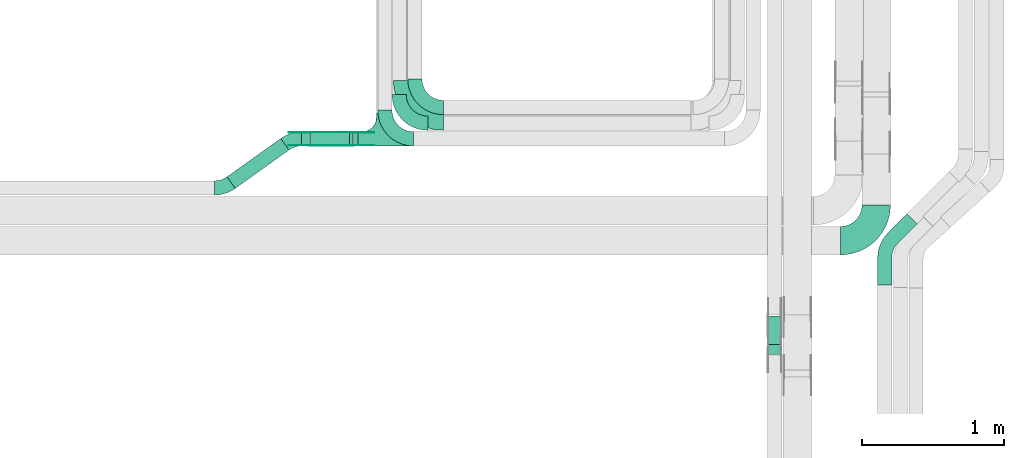
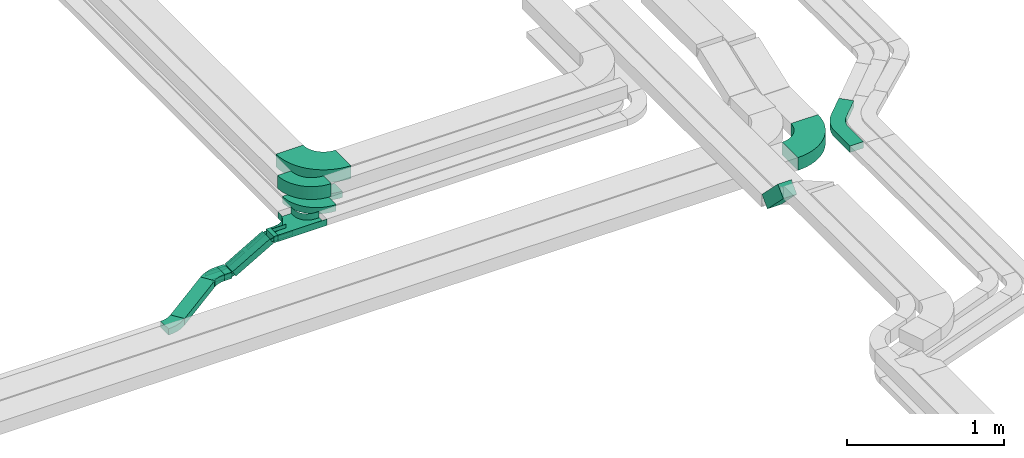
# One storey, part 21 of 25: 17 flow fittings, 5 flow segments.
"""IFC2X3 building model written with IfcOpenShell, lengths in millimetres."""

from ifc_helpers import new_model, entity, si_unit, converted_unit, derived_unit, direction, frame, frame_2d, origin, origin_2d_with_axis, place, context, subcontext, project, spatial, polyline, circle_curve, parameter, trimmed, segment, composite_curve, rectangle, outline, extrude, faceted_brep, source, transform, mapped, material, type_object, type_shapes, element, save


model = new_model("IFC2X3")

# Units and contexts
model_context = context("Model", 3, precision=0.01, world=origin(), true_north=direction((6.12303176911189e-17, 1.0)))
body_context = subcontext(model_context, "Body", "Model", "MODEL_VIEW")
ifc_project = project(units=[si_unit("LENGTHUNIT", "METRE", prefix="MILLI"), si_unit("AREAUNIT", "SQUARE_METRE"), si_unit("VOLUMEUNIT", "CUBIC_METRE"), converted_unit("PLANEANGLEUNIT", "DEGREE", entity("IfcRatioMeasure", 0.0174532925199433), si_unit("PLANEANGLEUNIT", "RADIAN"), dimensions=[0, 0, 0, 0, 0, 0, 0]), si_unit("MASSUNIT", "GRAM", prefix="KILO"), derived_unit("MASSDENSITYUNIT", [(si_unit("MASSUNIT", "GRAM", prefix="KILO"), 1), (si_unit("LENGTHUNIT", "METRE"), -3)]), derived_unit("MOMENTOFINERTIAUNIT", [(si_unit("LENGTHUNIT", "METRE"), 4)]), si_unit("TIMEUNIT", "SECOND"), si_unit("FREQUENCYUNIT", "HERTZ"), si_unit("THERMODYNAMICTEMPERATUREUNIT", "DEGREE_CELSIUS"), derived_unit("THERMALTRANSMITTANCEUNIT", [(si_unit("MASSUNIT", "GRAM", prefix="KILO"), 1), (si_unit("THERMODYNAMICTEMPERATUREUNIT", "KELVIN"), -1), (si_unit("TIMEUNIT", "SECOND"), -3)]), derived_unit("VOLUMETRICFLOWRATEUNIT", [(si_unit("LENGTHUNIT", "METRE"), 3), (si_unit("TIMEUNIT", "SECOND"), -1)]), derived_unit("MASSFLOWRATEUNIT", [(si_unit("MASSUNIT", "GRAM", prefix="KILO"), 1), (si_unit("TIMEUNIT", "SECOND"), -1)]), derived_unit("ROTATIONALFREQUENCYUNIT", [(si_unit("TIMEUNIT", "SECOND"), -1)]), si_unit("ELECTRICCURRENTUNIT", "AMPERE"), si_unit("ELECTRICVOLTAGEUNIT", "VOLT"), si_unit("POWERUNIT", "WATT"), si_unit("FORCEUNIT", "NEWTON", prefix="KILO"), si_unit("ILLUMINANCEUNIT", "LUX"), si_unit("LUMINOUSFLUXUNIT", "LUMEN"), si_unit("LUMINOUSINTENSITYUNIT", "CANDELA"), derived_unit("USERDEFINED", [(si_unit("MASSUNIT", "GRAM", prefix="KILO"), -1), (si_unit("LENGTHUNIT", "METRE"), -2), (si_unit("TIMEUNIT", "SECOND"), 3), (si_unit("LUMINOUSFLUXUNIT", "LUMEN"), 1)]), derived_unit("LINEARVELOCITYUNIT", [(si_unit("LENGTHUNIT", "METRE"), 1), (si_unit("TIMEUNIT", "SECOND"), -1)]), si_unit("PRESSUREUNIT", "PASCAL"), derived_unit("USERDEFINED", [(si_unit("LENGTHUNIT", "METRE"), -2), (si_unit("MASSUNIT", "GRAM", prefix="KILO"), 1), (si_unit("TIMEUNIT", "SECOND"), -2)]), derived_unit("LINEARFORCEUNIT", [(si_unit("MASSUNIT", "GRAM", prefix="KILO"), 1), (si_unit("LENGTHUNIT", "METRE"), 1), (si_unit("TIMEUNIT", "SECOND"), -2), (si_unit("LENGTHUNIT", "METRE"), -1)]), derived_unit("PLANARFORCEUNIT", [(si_unit("MASSUNIT", "GRAM", prefix="KILO"), 1), (si_unit("LENGTHUNIT", "METRE"), 1), (si_unit("TIMEUNIT", "SECOND"), -2), (si_unit("LENGTHUNIT", "METRE"), -2)])], contexts=[model_context])

# Site, building, storey
site_placement = place(None, frame((0.0, -0.00077364408347762, 0.0)))
site = spatial("IfcSite", under=ifc_project, at=site_placement, CompositionType="ELEMENT")
building_placement = place(site_placement, origin())
building = spatial("IfcBuilding", under=site, at=building_placement, CompositionType="ELEMENT")
storey_placement = place(building_placement, frame((0.0, 0.0, 24000.0)))
storey = spatial("IfcBuildingStorey", under=building, at=storey_placement, CompositionType="ELEMENT", Elevation=24000.0)

# Flow segments
cable_carrier_segment_type = type_object("IfcCableCarrierSegmentType", PredefinedType="CABLETRAYSEGMENT")
flow_segment_1_placement = place(storey_placement, frame((64748.84171246, 9500.0, 2972.82677247422)))
element("IfcFlowSegment", 1, at=flow_segment_1_placement, inside=storey, type_object=cable_carrier_segment_type, context=body_context, shape_type="SweptSolid", body=[
    extrude(rectangle(XDim=31.2393327962174, YDim=100.000000000001, at=origin_2d_with_axis()), frame((15.6196663981087, 50.0, 0.0), z_axis=(0.0, 0.0, 1.0), x_axis=(-1.0, 0.0, 0.0)), (0.0, 0.0, 1.0), 49.9999999999973),
])
flow_segment_2_placement = place(storey_placement, frame((64385.5720720537, 9500.0, 2805.0)))
element("IfcFlowSegment", 2, at=flow_segment_2_placement, inside=storey, type_object=cable_carrier_segment_type, context=body_context, shape_type="SweptSolid", body=[
    extrude(rectangle(XDim=54.6374214492034, YDim=99.9999999999989, at=origin_2d_with_axis()), frame((27.3187107246017, 50.0, 0.0)), (0.0, 0.0, 1.0), 49.9999999999973),
])
flow_segment_3_placement = place(storey_placement, frame((64444.0736377189, 9500.0, 2812.71695756239)))
element("IfcFlowSegment", 3, at=flow_segment_3_placement, inside=storey, type_object=cable_carrier_segment_type, context=body_context, shape_type="SweptSolid", body=[
    extrude(rectangle(XDim=49.9999999999914, YDim=100.000000000001, at=frame_2d((-3.75344200165273e-12, 0.0), x_axis=(1.0, 0.0))), frame((12.4862609703847, 50.0, 21.6585615168506), z_axis=(0.866342460674002, 0.0, 0.49945043881582), x_axis=(-0.49945043881582, 0.0, 0.866342460674002)), (0.0, 0.0, 1.0), 318.501540799204),
])
flow_segment_4_placement = place(storey_placement, frame((63861.3672984332, 9202.1366043859, 2805.0)))
element("IfcFlowSegment", 4, at=flow_segment_4_placement, inside=storey, type_object=cable_carrier_segment_type, context=body_context, shape_type="SweptSolid", body=[
    extrude(rectangle(XDim=463.396528175245, YDim=100.000000000006, at=frame_2d((3.5385028240853e-12, -2.51176857091195e-12), x_axis=(1.0, 0.0))), frame((217.602862273529, 175.358011276961, 0.0), z_axis=(0.0, 0.0, 1.0), x_axis=(-0.813735449455938, -0.581235424160247, 0.0)), (0.0, 0.0, 1.0), 49.9999999999973),
])
flow_segment_5_placement = place(storey_placement, frame((67656.3475285466, 8034.48081461932, 2986.43610045596)))
element("IfcFlowSegment", 5, at=flow_segment_5_placement, inside=storey, type_object=cable_carrier_segment_type, context=body_context, shape_type="SweptSolid", body=[
    extrude(rectangle(XDim=100.000000000001, YDim=99.9999999999946, at=frame_2d((0.0, 2.67519340013678e-12), x_axis=(0.0, 1.0))), frame((50.0, 237.9302604638, 35.35533905932), z_axis=(0.0, -0.70710678118652, 0.707106781186575), x_axis=(1.0, 0.0, 0.0)), (0.0, 0.0, 1.0), 286.484201246877),
])

# Flow fittings
ifc_material_1 = material(Name="G")
cable_carrier_fitting_type_1 = type_object("IfcCableCarrierFittingType", PredefinedType="NOTDEFINED", material=ifc_material_1)
shared_shape_1 = source(origin(), body_context, "Body", "SweptSolid", [
    extrude(outline(composite_curve([segment(trimmed(circle_curve(frame_2d((-44.5901162790698, 0.0), x_axis=(1.0, 0.0)), 12.5), [parameter(90.0000000000007)], [parameter(270.0)], True, "PARAMETER"), True, "CONTINUOUS"), segment(polyline([(-44.5901162790697, -12.5), (-33.0901162790698, -12.5)]), True, "CONTINUOUS"), segment(polyline([(-33.0901162790698, -12.5), (-31.2296511627907, -14.5)]), True, "CONTINUOUS"), segment(polyline([(-31.2296511627907, -14.5), (108.90988372093, -14.5)]), True, "CONTINUOUS"), segment(polyline([(108.90988372093, -14.5), (108.90988372093, 14.5)]), True, "CONTINUOUS"), segment(polyline([(108.90988372093, 14.5), (-31.2296511627907, 14.5)]), True, "CONTINUOUS"), segment(polyline([(-31.2296511627907, 14.5), (-33.0901162790698, 12.5)]), True, "CONTINUOUS"), segment(polyline([(-33.0901162790698, 12.5), (-44.5901162790699, 12.5)]), True, "CONTINUOUS")], self_intersect=False)), frame((44.5901162790698, 0.0, 0.0), z_axis=(0.0, 0.0, -1.0), x_axis=(1.0, 0.0, 0.0)), (0.0, 0.0, -1.0), 2.0),
])
type_shapes(cable_carrier_fitting_type_1, [shared_shape_1])
for number, where, z_axis, x_axis in (
    (6, (64740.0810452562, 9504.5399999898, 2997.82677247423), (0.0, -1.0, 0.0), (-0.866342460673953, 0.0, -0.499450438815904)),
    (7, (64448.9701607067, 9504.5399999898, 2830.0), (0.0, -1.0, 0.0), (0.866342460673953, 0.0, 0.499450438815904)),
):
    element("IfcFlowFitting", number, at=place(storey_placement, frame(where, z_axis=z_axis, x_axis=x_axis)), inside=storey, type_object=cable_carrier_fitting_type_1, material=ifc_material_1, context=body_context, shape_type="MappedRepresentation", body=[
        mapped(shared_shape_1, transform((0.0, 0.0, 0.0), scale=1.0)),
    ])
cable_carrier_fitting_type_2 = type_object("IfcCableCarrierFittingType", PredefinedType="NOTDEFINED", material=ifc_material_1)
shared_shape_2 = source(origin(), body_context, "Body", "SweptSolid", [
    extrude(outline(composite_curve([segment(trimmed(circle_curve(frame_2d((-44.5901162790697, 0.0), x_axis=(1.0, 0.0)), 12.5), [parameter(90.0000000000007)], [parameter(270.0)], True, "PARAMETER"), True, "CONTINUOUS"), segment(polyline([(-44.5901162790697, -12.5), (-33.0901162790697, -12.5)]), True, "CONTINUOUS"), segment(polyline([(-33.0901162790697, -12.5), (-31.2296511627907, -14.5)]), True, "CONTINUOUS"), segment(polyline([(-31.2296511627907, -14.5), (108.90988372093, -14.5)]), True, "CONTINUOUS"), segment(polyline([(108.90988372093, -14.5), (108.90988372093, 14.5)]), True, "CONTINUOUS"), segment(polyline([(108.90988372093, 14.5), (-31.2296511627907, 14.5)]), True, "CONTINUOUS"), segment(polyline([(-31.2296511627907, 14.5), (-33.0901162790698, 12.5)]), True, "CONTINUOUS"), segment(polyline([(-33.0901162790698, 12.5), (-44.5901162790699, 12.5)]), True, "CONTINUOUS")], self_intersect=False)), frame((44.5901162790697, 0.0, 0.0)), (0.0, 0.0, 1.0), 2.0),
])
type_shapes(cable_carrier_fitting_type_2, [shared_shape_2])
for number, where, z_axis, x_axis in (
    (8, (64740.0810452562, 9595.46000001012, 2997.82677247423), (0.0, 1.0, 0.0), (-0.866342460673953, 0.0, -0.499450438815904)),
    (9, (64448.9701607067, 9595.46000001012, 2830.0), (0.0, 1.0, 0.0), (0.866342460673953, 0.0, 0.499450438815904)),
):
    element("IfcFlowFitting", number, at=place(storey_placement, frame(where, z_axis=z_axis, x_axis=x_axis)), inside=storey, type_object=cable_carrier_fitting_type_2, material=ifc_material_1, context=body_context, shape_type="MappedRepresentation", body=[
        mapped(shared_shape_2, transform((0.0, 0.0, 0.0), scale=1.0)),
    ])
cable_carrier_fitting_type_3 = type_object("IfcCableCarrierFittingType", PredefinedType="NOTDEFINED", material=ifc_material_1)
shared_shape_3 = source(origin(), body_context, "Body", "SweptSolid", [
    extrude(outline(composite_curve([segment(trimmed(circle_curve(frame_2d((-44.5901162790698, 0.0), x_axis=(1.0, 0.0)), 12.5), [parameter(90.0000000000007)], [parameter(270.0)], True, "PARAMETER"), True, "CONTINUOUS"), segment(polyline([(-44.5901162790697, -12.5), (-33.0901162790698, -12.5)]), True, "CONTINUOUS"), segment(polyline([(-33.0901162790698, -12.5), (-31.2296511627907, -14.5)]), True, "CONTINUOUS"), segment(polyline([(-31.2296511627907, -14.5), (108.90988372093, -14.5)]), True, "CONTINUOUS"), segment(polyline([(108.90988372093, -14.5), (108.90988372093, 14.5)]), True, "CONTINUOUS"), segment(polyline([(108.90988372093, 14.5), (-31.2296511627907, 14.5)]), True, "CONTINUOUS"), segment(polyline([(-31.2296511627907, 14.5), (-33.0901162790698, 12.5)]), True, "CONTINUOUS"), segment(polyline([(-33.0901162790698, 12.5), (-44.5901162790699, 12.5)]), True, "CONTINUOUS")], self_intersect=False)), frame((44.5901162790698, 0.0, 0.0), z_axis=(0.0, 0.0, -1.0), x_axis=(1.0, 0.0, 0.0)), (0.0, 0.0, -1.0), 2.0),
])
type_shapes(cable_carrier_fitting_type_3, [shared_shape_3])
for number, where, z_axis, x_axis in (
    (10, (64740.0810452562, 9593.46000001012, 2997.82677247423), (0.0, 1.0, 0.0), (1.0, 0.0, 0.0)),
    (11, (64448.9701607067, 9593.46000001012, 2830.0), (0.0, 1.0, 0.0), (-1.0, 0.0, 0.0)),
):
    element("IfcFlowFitting", number, at=place(storey_placement, frame(where, z_axis=z_axis, x_axis=x_axis)), inside=storey, type_object=cable_carrier_fitting_type_3, material=ifc_material_1, context=body_context, shape_type="MappedRepresentation", body=[
        mapped(shared_shape_3, transform((0.0, 0.0, 0.0), scale=1.0)),
    ])
cable_carrier_fitting_type_4 = type_object("IfcCableCarrierFittingType", PredefinedType="NOTDEFINED", material=ifc_material_1)
shared_shape_4 = source(origin(), body_context, "Body", "SweptSolid", [
    extrude(outline(composite_curve([segment(trimmed(circle_curve(frame_2d((-44.5901162790697, 0.0), x_axis=(1.0, 0.0)), 12.5), [parameter(90.0000000000007)], [parameter(270.0)], True, "PARAMETER"), True, "CONTINUOUS"), segment(polyline([(-44.5901162790697, -12.5), (-33.0901162790697, -12.5)]), True, "CONTINUOUS"), segment(polyline([(-33.0901162790697, -12.5), (-31.2296511627907, -14.5)]), True, "CONTINUOUS"), segment(polyline([(-31.2296511627907, -14.5), (108.90988372093, -14.5)]), True, "CONTINUOUS"), segment(polyline([(108.90988372093, -14.5), (108.90988372093, 14.5)]), True, "CONTINUOUS"), segment(polyline([(108.90988372093, 14.5), (-31.2296511627907, 14.5)]), True, "CONTINUOUS"), segment(polyline([(-31.2296511627907, 14.5), (-33.0901162790698, 12.5)]), True, "CONTINUOUS"), segment(polyline([(-33.0901162790698, 12.5), (-44.5901162790699, 12.5)]), True, "CONTINUOUS")], self_intersect=False)), frame((44.5901162790697, 0.0, 0.0)), (0.0, 0.0, 1.0), 2.0),
])
type_shapes(cable_carrier_fitting_type_4, [shared_shape_4])
for number, where, z_axis, x_axis in (
    (12, (64740.0810452562, 9506.5399999898, 2997.82677247422), (0.0, -1.0, 0.0), (1.0, 0.0, 0.0)),
    (13, (64448.9701607067, 9506.5399999898, 2830.0), (0.0, -1.0, 0.0), (-1.0, 0.0, 0.0)),
):
    element("IfcFlowFitting", number, at=place(storey_placement, frame(where, z_axis=z_axis, x_axis=x_axis)), inside=storey, type_object=cable_carrier_fitting_type_4, material=ifc_material_1, context=body_context, shape_type="MappedRepresentation", body=[
        mapped(shared_shape_4, transform((0.0, 0.0, 0.0), scale=1.0)),
    ])
ifc_material_2 = material()
cable_carrier_fitting_type_5 = type_object("IfcCableCarrierFittingType", Name="470_DKC_S5_Variable Angle Elbow 0-45:-", PredefinedType="NOTDEFINED", material=ifc_material_2)
shared_shape_5 = source(origin(), body_context, "Body", "SweptSolid", [
    extrude(outline(composite_curve([segment(polyline([(-125.750000000001, -225.25), (-124.749999999999, -225.25)]), True, "CONTINUOUS"), segment(trimmed(circle_curve(frame_2d((-124.75, 124.75), x_axis=(0.0, -1.0)), 350.0), [parameter(0.0)], [parameter(90.0000000000001)], True, "PARAMETER"), True, "CONTINUOUS"), segment(polyline([(225.25, 124.75), (225.25, 125.749999999999)]), True, "CONTINUOUS"), segment(polyline([(225.25, 125.749999999999), (25.25, 125.750000000001)]), True, "CONTINUOUS"), segment(polyline([(25.25, 125.750000000001), (25.25, 124.75)]), True, "CONTINUOUS"), segment(trimmed(circle_curve(frame_2d((-124.75, 124.75), x_axis=(0.0, -1.0)), 150.0), [parameter(0.0)], [parameter(90.0000000000001)], True, "PARAMETER"), False, "CONTINUOUS"), segment(polyline([(-124.749999999999, -25.2500000000003), (-125.750000000001, -25.2500000000003)]), True, "CONTINUOUS"), segment(polyline([(-125.750000000001, -25.2500000000003), (-125.750000000001, -225.25)]), True, "CONTINUOUS")], self_intersect=False)), frame((-125.249999999991, 125.249999999992, -50.0)), (0.0, 0.0, 1.0), 100.0),
])
type_shapes(cable_carrier_fitting_type_5, [shared_shape_5])
flow_fitting_1_placement = place(storey_placement, frame((65130.0810452562, 9710.0, 3237.82677247422), z_axis=(0.0, 0.0, 1.0), x_axis=(0.0, -1.0, 0.0)))
element("IfcFlowFitting", 14, at=flow_fitting_1_placement, inside=storey, type_object=cable_carrier_fitting_type_5, material=ifc_material_2, Name="470_DKC_S5_Variable Angle Elbow 0-45:-", ObjectType="470_DKC_S5_Variable Angle Elbow 0-45:-", context=body_context, shape_type="MappedRepresentation", body=[
    mapped(shared_shape_5, transform((0.0, 0.0, 0.0), scale=1.0)),
])
flow_fitting_2_placement = place(storey_placement, frame((68419.2384978797, 8834.98923132602, 2855.0)))
element("IfcFlowFitting", 15, at=flow_fitting_2_placement, inside=storey, type_object=cable_carrier_fitting_type_5, material=ifc_material_2, Name="470_DKC_S5_Variable Angle Elbow 0-45:-", ObjectType="470_DKC_S5_Variable Angle Elbow 0-45:-", context=body_context, shape_type="MappedRepresentation", body=[
    mapped(shared_shape_5, transform((0.0, 0.0, 0.0), scale=1.0)),
])
cable_carrier_fitting_type_6 = type_object("IfcCableCarrierFittingType", Name="470_DKC_S5_Variable Angle Elbow 0-45:-", PredefinedType="NOTDEFINED", material=ifc_material_2)
shared_shape_6 = source(origin(), body_context, "Body", "SweptSolid", [
    extrude(outline(composite_curve([segment(polyline([(-100.749999999999, -150.250000000001), (-99.7499999999981, -150.250000000001)]), True, "CONTINUOUS"), segment(trimmed(circle_curve(frame_2d((-99.7500000000006, 99.7499999999987), x_axis=(0.0, -1.0)), 250.0), [parameter(0.0)], [parameter(90.0000000000001)], True, "PARAMETER"), True, "CONTINUOUS"), segment(polyline([(150.249999999999, 99.7500000000013), (150.249999999999, 100.750000000001)]), True, "CONTINUOUS"), segment(polyline([(150.249999999999, 100.750000000001), (50.2499999999992, 100.750000000001)]), True, "CONTINUOUS"), segment(polyline([(50.2499999999992, 100.750000000001), (50.2499999999992, 99.7500000000002)]), True, "CONTINUOUS"), segment(trimmed(circle_curve(frame_2d((-99.7500000000006, 99.7499999999987), x_axis=(0.0, -1.0)), 150.0), [parameter(0.0)], [parameter(90.0000000000001)], True, "PARAMETER"), False, "CONTINUOUS"), segment(polyline([(-99.7499999999989, -50.2500000000011), (-100.75, -50.2500000000011)]), True, "CONTINUOUS"), segment(polyline([(-100.75, -50.2500000000011), (-100.749999999999, -150.250000000001)]), True, "CONTINUOUS")], self_intersect=False)), frame((-100.249999999991, 100.249999999992, -50.0)), (0.0, 0.0, 1.0), 100.0),
])
type_shapes(cable_carrier_fitting_type_6, [shared_shape_6])
flow_fitting_3_placement = place(storey_placement, frame((64970.0810452562, 9550.0, 3237.82677247422), z_axis=(0.0, 0.0, 1.0), x_axis=(0.0, -1.0, 0.0)))
element("IfcFlowFitting", 16, at=flow_fitting_3_placement, inside=storey, type_object=cable_carrier_fitting_type_6, material=ifc_material_2, Name="470_DKC_S5_Variable Angle Elbow 0-45:-", ObjectType="470_DKC_S5_Variable Angle Elbow 0-45:-", context=body_context, shape_type="MappedRepresentation", body=[
    mapped(shared_shape_6, transform((0.0, 0.0, 0.0), scale=1.0)),
])
cable_carrier_fitting_type_7 = type_object("IfcCableCarrierFittingType", PredefinedType="NOTDEFINED", material=ifc_material_2)
shared_shape_7 = source(origin(), body_context, "Body", "Brep", [
    faceted_brep([(-53.4074173710859, -124.118095489752, 25.0), (-50.0, -150.0, 25.0), (-50.0, -180.0, 25.0), (-49.1999999999934, -180.0, 25.0), (-49.1999999999926, -150.0, 25.0), (-52.6346767100545, -123.91104025367, 25.0), (-62.7046392985216, -99.6000000000037, 25.0), (-78.7236364563899, -78.7236364563991, 25.0), (-99.5999999999949, -62.7046392985315, 25.0), (-123.911040253662, -52.6346767100651, 25.0), (-150.0, -49.2000000000047, 25.0), (-180.0, -49.2000000000047, 25.0), (-180.0, -50.0, 25.0), (-150.0, -50.0, 25.0), (-124.118095489745, -53.4074173710983, 25.0), (-100.0, -63.3974596215602, 25.0), (-79.2893218813398, -79.2893218813488, 25.0), (-63.3974596215496, -100.0, 25.0), (180.0, -50.0, 25.0), (180.0, -49.2000000000047, 25.0), (150.0, -49.2000000000046, 25.0), (123.911040253717, -52.634676710066, 25.0), (99.6000000000452, -62.7046392985316, 25.0), (78.7236364564342, -78.7236364563979, 25.0), (62.7046392985581, -99.6000000000012, 25.0), (52.6346767100809, -123.911040253668, 25.0), (49.200000000007, -150.0, 25.0), (49.2000000000071, -180.0, 25.0), (50.0, -180.0, 25.0), (50.0, -150.0, 25.0), (53.4074173711136, -124.11809548975, 25.0), (63.3974596215874, -100.0, 25.0), (79.2893218813853, -79.2893218813486, 25.0), (100.0, -63.3974596215613, 25.0), (124.1180954898, -53.4074173710999, 25.0), (150.0, -50.0, 25.0), (180.0, 49.1999999999958, 25.0), (180.0, 50.0, 25.0), (-180.0, 50.0, 25.0), (-180.0, 49.1999999999958, 25.0), (-180.0, -50.0, -25.0), (-180.0, 50.0, -25.0), (180.0, 50.0, -25.0), (180.0, -50.0, -25.0), (150.0, -50.0, -25.0), (124.1180954898, -53.4074173710999, -25.0), (100.0, -63.3974596215613, -25.0), (79.2893218813853, -79.2893218813486, -25.0), (63.3974596215874, -100.0, -25.0), (53.4074173711136, -124.11809548975, -25.0), (50.0, -150.0, -25.0), (50.0, -180.0, -25.0), (-50.0, -180.0, -25.0), (-50.0, -150.0, -25.0), (-53.4074173710859, -124.118095489752, -25.0), (-63.3974596215496, -100.0, -25.0), (-79.2893218813398, -79.2893218813488, -25.0), (-100.0, -63.3974596215602, -25.0), (-124.118095489745, -53.4074173710983, -25.0), (-150.0, -50.0, -25.0), (-50.0, -150.0, -24.199999999986), (49.2000000000071, -180.0, -24.199999999986), (-49.1999999999934, -180.0, -24.199999999986), (-49.1999999999926, -150.0, -24.199999999986), (-150.0, -49.2000000000047, -24.199999999986), (-180.0, -49.2000000000047, -24.199999999986), (180.0, -49.2000000000047, -24.199999999986), (150.0, -49.2000000000047, -24.199999999986), (-180.0, 49.1999999999958, -24.199999999986), (-150.0, -50.0, -24.199999999986), (150.0, -50.0, -24.199999999986), (180.0, 49.1999999999958, -24.199999999986), (49.200000000007, -150.0, -24.199999999986), (50.0, -150.0, -24.199999999986), (-123.911040253662, -52.6346767100651, -24.199999999986), (-99.5999999999949, -62.7046392985315, -24.199999999986), (-78.7236364563899, -78.7236364563991, -24.199999999986), (-62.7046392985217, -99.6000000000036, -24.199999999986), (-52.6346767100546, -123.91104025367, -24.199999999986), (52.6346767100807, -123.911040253669, -24.199999999986), (62.7046392985577, -99.6000000000018, -24.199999999986), (78.7236364564338, -78.7236364563983, -24.199999999986), (99.6000000000446, -62.704639298532, -24.199999999986), (123.911040253716, -52.6346767100662, -24.199999999986)], [[[0, 1, 2, 3, 4, 5, 6, 7, 8, 9, 10, 11, 12, 13, 14, 15, 16, 17]], [[18, 19, 20, 21, 22, 23, 24, 25, 26, 27, 28, 29, 30, 31, 32, 33, 34, 35]], [[36, 37, 38, 39]], [[40, 41, 42, 43, 44, 45, 46, 47, 48, 49, 50, 51, 52, 53, 54, 55, 56, 57, 58, 59]], [[2, 1, 60, 53, 52]], [[3, 2, 52, 51, 28, 27, 61, 62]], [[4, 3, 62, 63]], [[11, 10, 64, 65]], [[20, 19, 66, 67]], [[39, 38, 41, 40, 12, 11, 65, 68]], [[13, 12, 40, 59, 69]], [[18, 35, 70, 44, 43]], [[19, 18, 43, 42, 37, 36, 71, 66]], [[27, 26, 72, 61]], [[29, 28, 51, 50, 73]], [[38, 37, 42, 41]], [[36, 39, 68, 71]], [[68, 65, 64, 74, 75, 76, 77, 78, 63, 62, 61, 72, 79, 80, 81, 82, 83, 67, 66, 71]], [[14, 13, 69, 59, 58]], [[58, 57, 15, 14]], [[15, 57, 56, 16]], [[0, 17, 55, 54]], [[0, 54, 53, 60, 1]], [[55, 17, 16, 56]], [[5, 4, 63, 78]], [[6, 5, 78, 77]], [[7, 6, 77, 76]], [[8, 7, 76, 75]], [[9, 8, 75, 74]], [[10, 9, 74, 64]], [[21, 20, 67, 83]], [[22, 21, 83, 82]], [[23, 22, 82, 81]], [[81, 80, 24, 23]], [[24, 80, 79, 25]], [[79, 72, 26, 25]], [[30, 29, 73, 50, 49]], [[31, 30, 49, 48]], [[31, 48, 47, 32]], [[33, 32, 47, 46]], [[45, 34, 33, 46]], [[34, 45, 44, 70, 35]]]),
])
type_shapes(cable_carrier_fitting_type_7, [shared_shape_7])
flow_fitting_4_placement = place(storey_placement, frame((64960.0810452562, 9550.0, 2997.82677247422), z_axis=(0.0, 0.0, 1.0), x_axis=(-1.0, 0.0, 0.0)))
element("IfcFlowFitting", 17, at=flow_fitting_4_placement, inside=storey, type_object=cable_carrier_fitting_type_7, material=ifc_material_2, Name="470_DKC_S5_T", context=body_context, shape_type="MappedRepresentation", body=[
    mapped(shared_shape_7, transform((0.0, 0.0, 0.0), scale=1.0)),
])
cable_carrier_fitting_type_8 = type_object("IfcCableCarrierFittingType", Name="470_DKC_S5_Variable Angle Elbow 0-45:-", PredefinedType="NOTDEFINED", material=ifc_material_2)
shared_shape_8 = source(origin(), body_context, "Body", "SweptSolid", [
    extrude(outline(composite_curve([segment(polyline([(-100.750000000001, -150.25), (-99.7499999999994, -150.25)]), True, "CONTINUOUS"), segment(trimmed(circle_curve(frame_2d((-99.7499999999997, 99.7499999999995), x_axis=(0.0, -1.0)), 250.0), [parameter(0.0)], [parameter(90.0000000000001)], True, "PARAMETER"), True, "CONTINUOUS"), segment(polyline([(150.25, 99.75), (150.25, 100.749999999999)]), True, "CONTINUOUS"), segment(polyline([(150.25, 100.749999999999), (50.25, 100.75)]), True, "CONTINUOUS"), segment(polyline([(50.25, 100.75), (50.25, 99.7499999999998)]), True, "CONTINUOUS"), segment(trimmed(circle_curve(frame_2d((-99.7499999999997, 99.7499999999995), x_axis=(0.0, -1.0)), 150.0), [parameter(0.0)], [parameter(90.0000000000001)], True, "PARAMETER"), False, "CONTINUOUS"), segment(polyline([(-99.7499999999994, -50.2500000000003), (-100.750000000001, -50.2500000000003)]), True, "CONTINUOUS"), segment(polyline([(-100.750000000001, -50.2500000000003), (-100.750000000001, -150.25)]), True, "CONTINUOUS")], self_intersect=False)), frame((-100.249999999991, 100.249999999992, -25.0)), (0.0, 0.0, 1.0), 49.9999999999997),
])
type_shapes(cable_carrier_fitting_type_8, [shared_shape_8])
for number, where, z_axis, x_axis, name in (
    (18, (65180.0810452562, 9770.0, 2997.82677247422), (0.0, 0.0, 1.0), (0.0, -1.0, 0.0), "470_DKC_S5_Variable Angle Elbow 0-45:-"),
    (19, (65070.0810452562, 9660.0, 2997.82677247422), (0.0, 0.0, 1.0), (0.0, -1.0, 0.0), "470_DKC_S5_Variable Angle Elbow 0-45:-"),
):
    element("IfcFlowFitting", number, at=place(storey_placement, frame(where, z_axis=z_axis, x_axis=x_axis)), inside=storey, type_object=cable_carrier_fitting_type_8, material=ifc_material_2, Name=name, ObjectType="470_DKC_S5_Variable Angle Elbow 0-45:-", context=body_context, shape_type="MappedRepresentation", body=[
        mapped(shared_shape_8, transform((0.0, 0.0, 0.0), scale=1.0)),
    ])
cable_carrier_fitting_type_9 = type_object("IfcCableCarrierFittingType", Name="470_DKC_S5_Variable Angle Elbow 0-45:-", PredefinedType="NOTDEFINED", material=ifc_material_2)
shared_shape_9 = source(origin(), body_context, "Body", "SweptSolid", [
    extrude(outline(composite_curve([segment(polyline([(-59.0769762783848, -68.7717639104429), (-58.0769762783835, -68.7717639104429)]), True, "CONTINUOUS"), segment(trimmed(circle_curve(frame_2d((-58.076976278384, 181.228236089557), x_axis=(0.0, -1.0)), 250.0), [parameter(0.0)], [parameter(35.5374827848269)], True, "PARAMETER"), True, "CONTINUOUS"), segment(polyline([(87.2318797616659, -22.2056262744358), (88.0456152111218, -21.6243908502757)]), True, "CONTINUOUS"), segment(polyline([(88.0456152111218, -21.6243908502757), (29.922072795102, 59.7491540953215)]), True, "CONTINUOUS"), segment(polyline([(29.922072795102, 59.7491540953215), (29.108337345646, 59.1679186711612)]), True, "CONTINUOUS"), segment(trimmed(circle_curve(frame_2d((-58.076976278384, 181.228236089557), x_axis=(0.0, -1.0)), 150.0), [parameter(0.0)], [parameter(35.5374827848269)], True, "PARAMETER"), False, "CONTINUOUS"), segment(polyline([(-58.0769762783835, 31.228236089557), (-59.0769762783848, 31.228236089557)]), True, "CONTINUOUS"), segment(polyline([(-59.0769762783848, 31.228236089557), (-59.0769762783848, -68.7717639104429)]), True, "CONTINUOUS")], self_intersect=False)), frame((-6.01565909845144, 18.7717639104348, -25.0)), (0.0, 0.0, 1.0), 50.0),
])
type_shapes(cable_carrier_fitting_type_9, [shared_shape_9])
flow_fitting_5_placement = place(storey_placement, frame((64320.4794366769, 9550.0, 2830.0), z_axis=(0.0, 0.0, 1.0), x_axis=(-1.0, 0.0, 0.0)))
element("IfcFlowFitting", 20, at=flow_fitting_5_placement, inside=storey, type_object=cable_carrier_fitting_type_9, material=ifc_material_2, Name="470_DKC_S5_Variable Angle Elbow 0-45:-", ObjectType="470_DKC_S5_Variable Angle Elbow 0-45:-", context=body_context, shape_type="MappedRepresentation", body=[
    mapped(shared_shape_9, transform((0.0, 0.0, 0.0), scale=1.0)),
])
flow_fitting_6_placement = place(storey_placement, frame((63837.4608847365, 9204.98923132574, 2830.0)))
element("IfcFlowFitting", 21, at=flow_fitting_6_placement, inside=storey, type_object=cable_carrier_fitting_type_9, material=ifc_material_2, Name="470_DKC_S5_Variable Angle Elbow 0-45:-", ObjectType="470_DKC_S5_Variable Angle Elbow 0-45:-", context=body_context, shape_type="MappedRepresentation", body=[
    mapped(shared_shape_9, transform((0.0, 0.0, 0.0), scale=1.0)),
])
cable_carrier_fitting_type_10 = type_object("IfcCableCarrierFittingType", Name="470_DKC_S5_CS 90 internal vertical angle:-", PredefinedType="NOTDEFINED", material=ifc_material_2)
shared_shape_10 = source(origin(), body_context, "Body", "SweptSolid", [
    extrude(outline(composite_curve([segment(polyline([(-246.186418404585, -112.760191002141), (-56.8465901844057, -112.760191002141)]), True, "CONTINUOUS"), segment(trimmed(circle_curve(frame_2d((-56.8465901844061, 137.239808997858), x_axis=(0.0, -1.0)), 249.999999999999), [parameter(0.0)], [parameter(45.0)], True, "PARAMETER"), True, "CONTINUOUS"), segment(polyline([(119.93010511223, -39.5368862987784), (253.813581595415, 94.3465901844058)]), True, "CONTINUOUS"), segment(polyline([(253.813581595415, 94.3465901844057), (183.10290347676, 165.057268303061)]), True, "CONTINUOUS"), segment(polyline([(183.10290347676, 165.057268303061), (49.2194269935753, 31.1737918198764)]), True, "CONTINUOUS"), segment(trimmed(circle_curve(frame_2d((-56.8465901844061, 137.239808997858), x_axis=(0.0, -1.0)), 149.999999999999), [parameter(0.0)], [parameter(45.0)], True, "PARAMETER"), False, "CONTINUOUS"), segment(polyline([(-56.8465901844057, -12.7601910021412), (-246.186418404585, -12.7601910021412)]), True, "CONTINUOUS"), segment(polyline([(-246.186418404585, -12.7601910021412), (-246.186418404585, -112.760191002141)]), True, "CONTINUOUS")], self_intersect=False)), frame((-25.9961222902041, 62.760191002134, -25.0)), (0.0, 0.0, 1.0), 49.9999999999999),
])
type_shapes(cable_carrier_fitting_type_10, [shared_shape_10])
flow_fitting_7_placement = place(storey_placement, frame((68479.0864961081, 8796.10238695343, 3004.67076557722), z_axis=(0.00385230234690328, 0.00508717587948003, 0.999979639996835), x_axis=(-0.707092654053961, -0.707092654053894, 0.00632116808395283)))
element("IfcFlowFitting", 22, at=flow_fitting_7_placement, inside=storey, type_object=cable_carrier_fitting_type_10, material=ifc_material_2, Name="470_DKC_S5_CS 90 internal vertical angle:-", ObjectType="470_DKC_S5_CS 90 internal vertical angle:-", context=body_context, shape_type="MappedRepresentation", body=[
    mapped(shared_shape_10, transform((0.0, 0.0, 0.0), scale=1.0)),
])

save(model, "model.ifc")
